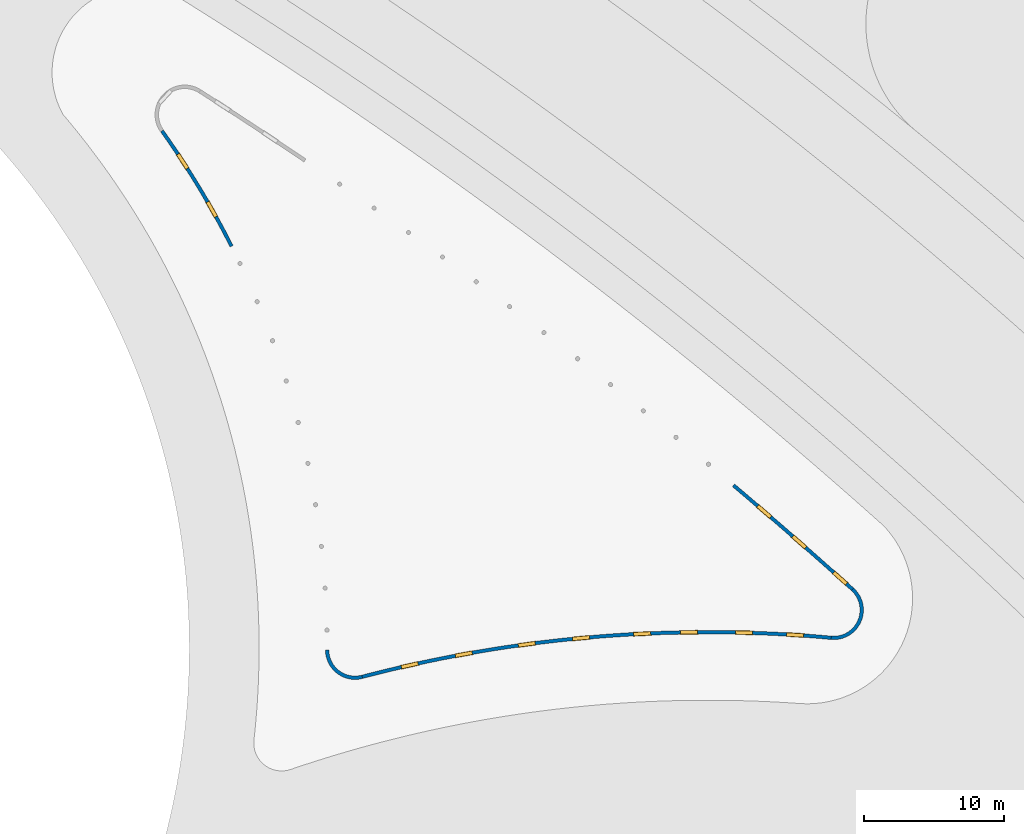
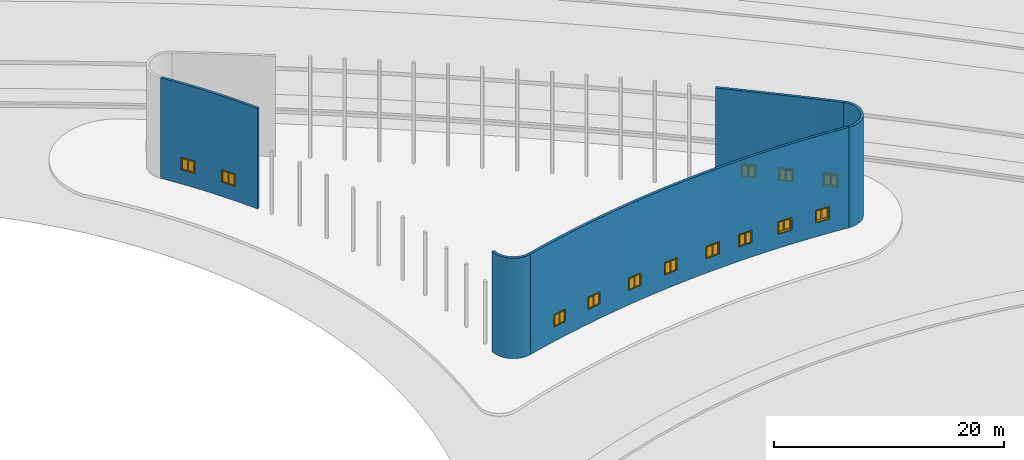
# One storey, part 13 of 39: 13 windows, 5 walls, 13 openings.
"""IFC2X3 building model written with IfcOpenShell, lengths in millimetres."""

from ifc_helpers import new_model, entity, si_unit, converted_unit, derived_unit, direction, frame, frame_2d, origin, origin_2d_with_axis, place, context, subcontext, project, spatial, polyline, circle_curve, parameter, trimmed, segment, composite_curve, rectangle, outline, extrude, clip, halfspace, source, transform, mapped, material, material_list, layer, layer_set, layer_usage, type_object, type_shapes, element, fill, save


model = new_model("IFC2X3")

# Units and contexts
model_context = context("Model", 3, precision=1e-06, world=origin(), true_north=direction((2.0, 6.12303176911189e-17, 1.0)))
context_of_model = context(None, 3, precision=1e-06, world=origin(), true_north=direction((2.0, 6.12303176911189e-17, 1.0)))
body_context = subcontext(model_context, "Body", "Model", "MODEL_VIEW")
ifc_project = project(units=[si_unit("LENGTHUNIT", "METRE", prefix="MILLI"), si_unit("AREAUNIT", "SQUARE_METRE", prefix="MILLI"), si_unit("VOLUMEUNIT", "CUBIC_METRE", prefix="MILLI"), converted_unit("PLANEANGLEUNIT", "DEGREE", entity("IfcRatioMeasure", 0.0174532925199433), si_unit("PLANEANGLEUNIT", "RADIAN"), dimensions=[0, 0, 0, 0, 0, 0, 0]), si_unit("MASSUNIT", "GRAM", prefix="KILO"), si_unit("TIMEUNIT", "SECOND"), si_unit("THERMODYNAMICTEMPERATUREUNIT", "KELVIN"), derived_unit("THERMALTRANSMITTANCEUNIT", [(si_unit("MASSUNIT", "GRAM", prefix="KILO"), 1), (si_unit("THERMODYNAMICTEMPERATUREUNIT", "KELVIN"), -1), (si_unit("TIMEUNIT", "SECOND"), -3)]), derived_unit("VOLUMETRICFLOWRATEUNIT", [(si_unit("LENGTHUNIT", "METRE"), 3), (si_unit("TIMEUNIT", "SECOND"), -1)])], contexts=[model_context, context_of_model])

# Site, building, storey
site_placement = place(None, origin())
site = spatial("IfcSite", under=ifc_project, at=site_placement, CompositionType="ELEMENT")
building_placement = place(site_placement, origin())
building = spatial("IfcBuilding", under=site, at=building_placement, CompositionType="ELEMENT")
storey_placement = place(building_placement, frame((0.0, 0.0, 4000.0)))
storey = spatial("IfcBuildingStorey", under=building, at=storey_placement, Name="Level 2", CompositionType="ELEMENT", Elevation=4000.0)

# Wall, openings, windows
ifc_material_1 = material(Name="Concrete - Cast In Situ")
ifc_layer = layer(ifc_material_1, 250.0)
ifc_layer_set = layer_set([ifc_layer], Name="Basic Wall:Structure wall")
ifc_layer_usage_1 = layer_usage(ifc_layer_set, "AXIS2", "POSITIVE", -125.0)
wall_type = type_object("IfcWallType", Name="Basic Wall:Structure wall", PredefinedType="STANDARD", material=ifc_layer_set)
wall_1_placement = place(storey_placement, frame((324246.856857284, 630373.986628821, 362.0)))
wall_1 = element("IfcWallStandardCase", 1, at=wall_1_placement, inside=storey, type_object=wall_type, material=ifc_layer_usage_1, Name="Basic Wall:Structure wall", ObjectType="Basic Wall:Structure wall", context=body_context, shape_type="Clipping", body=[
    clip(extrude(outline(composite_curve([segment(trimmed(circle_curve(frame_2d((-52045.9791286695, -37030.145578138), x_axis=(1.0, 0.0)), 64000.0), [parameter(26.776901044259)], [parameter(35.4314354354956)], True, "PARAMETER"), True, "CONTINUOUS"), segment(polyline([(101.851231171776, 72.4660383130737), (-101.851231171568, -72.4660383133509)]), True, "CONTINUOUS"), segment(trimmed(circle_curve(frame_2d((-52045.9791286695, -37030.145578138), x_axis=(1.0, 0.0)), 63750.0), [parameter(26.776901044259)], [parameter(35.4314354354956)], True, "PARAMETER"), False, "CONTINUOUS"), segment(polyline([(4867.95017362721, -8309.64503630951), (5091.14205324426, -8197.01562242035)]), True, "CONTINUOUS")], self_intersect=False)), origin(), (0.0, 0.0, 1.0), 10638.0), halfspace(frame((5091.14205324402, -8197.01562242, 10638.0)), False)),
])
opening_1_placement = place(wall_1_placement, frame((3978.539596587, -6084.61068482622, 1553.0)))
opening_1 = element("IfcOpeningElement", 2, at=opening_1_placement, cuts=wall_1, Name="M_Casement Dbl with Trim:1220 x 1220mm:1220 x 1220mm:1", ObjectType="Opening", context=body_context, shape_type="SweptSolid", body=[
    extrude(rectangle(XDim=1220.0, YDim=1220.0, at=frame_2d((610.0, 610.0), x_axis=(-1.0, 0.0))), frame((0.0, 0.0, 0.0), z_axis=(-0.870695342057725, -0.491822753966285, 0.0), x_axis=(0.0, 0.0, 1.0)), (0.0, 0.0, 1.0), 253.035095884814),
])
opening_2_placement = place(wall_1_placement, frame((1920.0419499185, -2620.24297474214, 1553.0)))
opening_2 = element("IfcOpeningElement", 3, at=opening_2_placement, cuts=wall_1, Name="M_Casement Dbl with Trim:1220 x 1220mm:1220 x 1220mm:1", ObjectType="Opening", context=body_context, shape_type="SweptSolid", body=[
    extrude(rectangle(XDim=1220.0, YDim=1220.0, at=frame_2d((610.0, 610.0), x_axis=(-1.0, 0.0))), frame((0.0, 0.0, 0.0), z_axis=(-0.838018354143229, -0.545642042111011, 0.0), x_axis=(0.0, 0.0, 1.0)), (0.0, 0.0, 1.0), 253.035095884814),
])
ifc_material_2 = material(Name="Glass")
ifc_material_3 = material(Name="Sash")
ifc_material_4 = material(Name="Trim")
ifc_material_list_1 = material_list([ifc_material_2, ifc_material_3, ifc_material_4])
ifc_material_list_2 = material_list([ifc_material_2, ifc_material_3, ifc_material_4])
window_style = type_object("IfcWindowStyle", Name="1220 x 1220mm", ConstructionType="NOTDEFINED", OperationType="NOTDEFINED", ParameterTakesPrecedence=False, Sizeable=False, material=ifc_material_list_2)
shared_shape = source(origin(), body_context, "Body", "SweptSolid", [
    extrude(rectangle(XDim=12.7, YDim=482.999999999998, at=origin_2d_with_axis()), frame((915.0, 208.775, 63.5000000000002), z_axis=(0.0, 0.0, 1.0), x_axis=(0.0, -1.0, 0.0)), (0.0, 0.0, 1.0), 1093.0),
    extrude(outline(polyline([(-285.949999999999, -590.950000000002), (285.949999999999, -590.950000000002), (285.949999999999, 590.950000000003), (-285.949999999999, 590.950000000003), (-285.949999999999, -590.950000000002)]), holes=[polyline([(-241.499999999998, -546.500000000003), (-241.499999999998, 546.500000000002), (241.5, 546.500000000002), (241.5, -546.500000000003), (-241.499999999998, -546.500000000003)])]), frame((915.0, 186.55, 610.0), z_axis=(0.0, 1.0, 0.0), x_axis=(1.0, 0.0, 0.0)), (0.0, 0.0, 1.0), 44.45),
    extrude(rectangle(XDim=25.7, YDim=1359.89999999999, at=frame_2d((-1.68753899743024e-14, 0.0), x_axis=(1.0, 0.0))), frame((610.0, 262.85, 0.0), z_axis=(0.0, 0.0, 1.0), x_axis=(0.0, -1.0, 0.0)), (0.0, 0.0, 1.0), 19.0500000000014),
    extrude(outline(polyline([(-568.700000000007, 590.949999999995), (613.200000000007, 590.949999999995), (613.200000000007, 679.949999999994), (-657.700000000005, 679.949999999994), (-657.700000000005, -679.949999999993), (613.200000000006, -679.949999999993), (613.200000000006, -590.949999999995), (-568.700000000007, -590.949999999995), (-568.700000000007, 590.949999999995)])), frame((610.0, 250.0, 632.250000000007), z_axis=(0.0, 1.0, 0.0), x_axis=(0.0, 0.0, -1.0)), (0.0, 0.0, 1.0), 13.0),
    extrude(outline(polyline([(-667.25000000001, -667.249999999998), (667.25000000001, -667.249999999998), (667.25000000001, 667.249999999998), (-667.25000000001, 667.249999999998), (-667.25000000001, -667.249999999998)]), holes=[polyline([(-578.250000000011, -578.250000000001), (-578.250000000011, 578.249999999997), (578.24999999999, 578.249999999997), (578.24999999999, -578.250000000001), (-578.250000000011, -578.250000000001)])]), frame((610.0, -19.0, 610.0), z_axis=(0.0, 1.0, 0.0), x_axis=(0.0, 0.0, -1.0)), (0.0, 0.0, 1.0), 19.0),
    extrude(rectangle(XDim=12.7, YDim=482.999999999998, at=frame_2d((1.68753899743024e-14, 4.2632564145606e-14), x_axis=(1.0, 0.0))), frame((305.0, 208.775, 63.4999999999994), z_axis=(0.0, 0.0, 1.0), x_axis=(0.0, 1.0, 0.0)), (0.0, 0.0, 1.0), 1093.0),
    extrude(outline(polyline([(-285.949999999999, -590.950000000002), (285.949999999999, -590.950000000002), (285.949999999999, 590.950000000002), (-285.949999999999, 590.950000000002), (-285.949999999999, -590.950000000002)]), holes=[polyline([(-241.499999999999, -546.500000000003), (-241.499999999999, 546.500000000001), (241.499999999999, 546.500000000001), (241.499999999999, -546.500000000003), (-241.499999999999, -546.500000000003)])]), frame((305.0, 186.55, 610.0), z_axis=(0.0, 1.0, 0.0), x_axis=(1.0, 0.0, 0.0)), (0.0, 0.0, 1.0), 44.45),
    extrude(outline(polyline([(-610.0, -610.0), (610.0, -610.0), (610.0, 610.0), (-610.0, 610.0), (-610.0, -610.0)]), holes=[polyline([(-578.25, -578.250000000001), (-578.25, 578.25), (578.249999999997, 578.25), (578.249999999997, -578.250000000001), (-578.25, -578.250000000001)])]), frame((610.0, 0.0, 610.0), z_axis=(0.0, 1.0, 0.0), x_axis=(1.0, 0.0, 0.0)), (0.0, 0.0, 1.0), 186.55),
    extrude(outline(polyline([(-610.0, -610.0), (610.0, -610.0), (610.0, 610.0), (-610.0, 610.0), (-610.0, -610.0)]), holes=[polyline([(-590.950000000002, -590.949999999996), (-590.950000000002, 590.95), (590.950000000003, 590.95), (590.950000000003, -590.949999999996), (-590.950000000002, -590.949999999996)])]), frame((610.0, 186.55, 610.0), z_axis=(0.0, 1.0, 0.0), x_axis=(0.0, 0.0, -1.0)), (0.0, 0.0, 1.0), 63.45),
    extrude(rectangle(XDim=63.5, YDim=38.0999999999998, at=frame_2d((-8.88178419700125e-15, 0.0), x_axis=(1.0, 0.0))), frame((610.0, 218.3, 19.0499999999995), z_axis=(0.0, 0.0, 1.0), x_axis=(0.0, 1.0, 0.0)), (0.0, 0.0, 1.0), 1181.90000000001),
])
type_shapes(window_style, [shared_shape])
window_1_placement = place(opening_1_placement, frame((-2.53614969894988, -1.43257471255492, 0.0), z_axis=(0.0, 0.0, 1.0), x_axis=(-0.491822753966285, 0.870695342057725, 0.0)))
window_1 = element("IfcWindow", 4, at=window_1_placement, inside=storey, type_object=window_style, material=ifc_material_list_1, Name="M_Casement Dbl with Trim:1220 x 1220mm", ObjectType="1220 x 1220mm", OverallHeight=1220.0, OverallWidth=1220.00000000006, context=body_context, shape_type="MappedRepresentation", body=[
    mapped(shared_shape, transform((0.0, 0.0, 0.0), scale=1.0)),
])
fill(opening_1, window_1)
ifc_material_list_3 = material_list([ifc_material_2, ifc_material_3, ifc_material_4])
window_2_placement = place(opening_2_placement, frame((-2.44096860737773, -1.589338812395, 0.0), z_axis=(0.0, 0.0, 1.0), x_axis=(-0.545642042111011, 0.838018354143229, 0.0)))
window_2 = element("IfcWindow", 5, at=window_2_placement, inside=storey, type_object=window_style, material=ifc_material_list_3, Name="M_Casement Dbl with Trim:1220 x 1220mm", ObjectType="1220 x 1220mm", OverallHeight=1220.0, OverallWidth=1220.00000000006, context=body_context, shape_type="MappedRepresentation", body=[
    mapped(shared_shape, transform((0.0, 0.0, 0.0), scale=1.0)),
])
fill(opening_2, window_2)

ifc_layer_usage_2 = layer_usage(ifc_layer_set, "AXIS2", "POSITIVE", -125.0)
wall_2_placement = place(storey_placement, frame((338584.140354798, 591273.768990877, 362.0)))
wall_2 = element("IfcWallStandardCase", 6, at=wall_2_placement, inside=storey, type_object=wall_type, material=ifc_layer_usage_2, Name="Basic Wall:Structure wall", ObjectType="Basic Wall:Structure wall", context=body_context, shape_type="Clipping", body=[
    clip(extrude(outline(composite_curve([segment(trimmed(circle_curve(frame_2d((24750.1675326129, -94166.1613558314), x_axis=(1.0, 0.0)), 97489.453150957), [parameter(84.7874816270728)], [parameter(104.72626174384)], True, "PARAMETER"), True, "CONTINUOUS"), segment(polyline([(-31.7751586065948, 120.893917529113), (31.7751586072185, -120.893917528836)]), True, "CONTINUOUS"), segment(trimmed(circle_curve(frame_2d((24750.1675326129, -94166.1613558314), x_axis=(1.0, 0.0)), 97239.453150957), [parameter(84.7874816270728)], [parameter(104.72626174384)], True, "PARAMETER"), False, "CONTINUOUS"), segment(polyline([(33584.3879593551, 2671.16511773909), (33607.1005007688, 2920.13126094443)]), True, "CONTINUOUS")], self_intersect=False)), origin(), (0.0, 0.0, 1.0), 10638.0), halfspace(frame((33607.1005007689, 2920.1312609444, 10638.0)), False)),
])
opening_3_placement = place(wall_2_placement, frame((3973.79947671658, 1085.65533974674, 1553.0)))
opening_3 = element("IfcOpeningElement", 7, at=opening_3_placement, cuts=wall_2, Name="M_Casement Dbl with Trim:1220 x 1220mm:1220 x 1220mm:1", ObjectType="Opening", context=body_context, shape_type="SweptSolid", body=[
    extrude(rectangle(XDim=1220.0, YDim=1220.0, at=frame_2d((610.0, 610.0), x_axis=(-1.0, 0.0))), frame((0.0, 0.0, 0.0), z_axis=(0.219218889911997, -0.975675703451588, 0.0), x_axis=(0.0, 0.0, 1.0)), (0.0, 0.0, 1.0), 251.991120195076),
])
opening_4_placement = place(wall_2_placement, frame((7857.05191083967, 1850.44500989823, 1553.0)))
opening_4 = element("IfcOpeningElement", 8, at=opening_4_placement, cuts=wall_2, Name="M_Casement Dbl with Trim:1220 x 1220mm:1220 x 1220mm:1", ObjectType="Opening", context=body_context, shape_type="SweptSolid", body=[
    extrude(rectangle(XDim=1220.0, YDim=1220.0, at=frame_2d((610.0, 610.0), x_axis=(-1.0, 0.0))), frame((0.0, 0.0, 0.0), z_axis=(0.179436995405594, -0.98376946724312, 0.0), x_axis=(0.0, 0.0, 1.0)), (0.0, 0.0, 1.0), 251.991120195076),
])
opening_5_placement = place(wall_2_placement, frame((12377.3745818733, 2536.8895164147, 1553.0)))
opening_5 = element("IfcOpeningElement", 9, at=opening_5_placement, cuts=wall_2, Name="M_Casement Dbl with Trim:1220 x 1220mm:1220 x 1220mm:1", ObjectType="Opening", context=body_context, shape_type="SweptSolid", body=[
    extrude(rectangle(XDim=1220.0, YDim=1220.0, at=frame_2d((610.0, 610.0), x_axis=(-1.0, 0.0))), frame((0.0, 0.0, 0.0), z_axis=(0.133115568133921, -0.9911005224095, 0.0), x_axis=(0.0, 0.0, 1.0)), (0.0, 0.0, 1.0), 251.991120195076),
])
opening_6_placement = place(wall_2_placement, frame((16271.7719571808, 2955.83853023235, 1553.0)))
opening_6 = element("IfcOpeningElement", 10, at=opening_6_placement, cuts=wall_2, Name="M_Casement Dbl with Trim:1220 x 1220mm:1220 x 1220mm:1", ObjectType="Opening", context=body_context, shape_type="SweptSolid", body=[
    extrude(rectangle(XDim=1220.0, YDim=1220.0, at=frame_2d((610.0, 610.0), x_axis=(-1.0, 0.0))), frame((0.0, 0.0, 0.0), z_axis=(0.0931971627082571, -0.995647673056654, 0.0), x_axis=(0.0, 0.0, 1.0)), (0.0, 0.0, 1.0), 251.991120195076),
])
opening_7_placement = place(wall_2_placement, frame((20660.8314802058, 3239.40000517386, 1553.0)))
opening_7 = element("IfcOpeningElement", 11, at=opening_7_placement, cuts=wall_2, Name="M_Casement Dbl with Trim:1220 x 1220mm:1220 x 1220mm:1", ObjectType="Opening", context=body_context, shape_type="SweptSolid", body=[
    extrude(rectangle(XDim=1220.0, YDim=1220.0, at=frame_2d((610.0, 610.0), x_axis=(-1.0, 0.0))), frame((0.0, 0.0, 0.0), z_axis=(0.0481962601317734, -0.998837884999017, 0.0), x_axis=(0.0, 0.0, 1.0)), (0.0, 0.0, 1.0), 251.991120195076),
])
opening_8_placement = place(wall_2_placement, frame((24003.0360380399, 3322.33975035998, 1553.0)))
opening_8 = element("IfcOpeningElement", 12, at=opening_8_placement, cuts=wall_2, Name="M_Casement Dbl with Trim:1220 x 1220mm:1220 x 1220mm:1", ObjectType="Opening", context=body_context, shape_type="SweptSolid", body=[
    extrude(rectangle(XDim=1220.0, YDim=1220.0, at=frame_2d((610.0, 610.0), x_axis=(-1.0, 0.0))), frame((0.0, 0.0, 0.0), z_axis=(0.0139201966296798, -0.999903109368998, 0.0), x_axis=(0.0, 0.0, 1.0)), (0.0, 0.0, 1.0), 251.991120195076),
])
opening_9_placement = place(wall_2_placement, frame((26743.0473550544, 3050.95680832148, 1553.0)))
opening_9 = element("IfcOpeningElement", 13, at=opening_9_placement, cuts=wall_2, Name="M_Casement Dbl with Trim:1220 x 1220mm:1220 x 1220mm:1", ObjectType="Opening", context=body_context, shape_type="SweptSolid", body=[
    extrude(rectangle(XDim=1220.0, YDim=1220.0, at=frame_2d((610.0, 610.0), x_axis=(-1.0, 0.0))), frame((0.0, 0.0, 0.0), z_axis=(0.0267665391308398, 0.999641712006335, 0.0), x_axis=(0.0, 0.0, 1.0)), (0.0, 0.0, 1.0), 251.991120195076),
])
opening_10_placement = place(wall_2_placement, frame((30397.5170689068, 2907.24940810782, 1553.0)))
opening_10 = element("IfcOpeningElement", 14, at=opening_10_placement, cuts=wall_2, Name="M_Casement Dbl with Trim:1220 x 1220mm:1220 x 1220mm:1", ObjectType="Opening", context=body_context, shape_type="SweptSolid", body=[
    extrude(rectangle(XDim=1220.0, YDim=1220.0, at=frame_2d((610.0, 610.0), x_axis=(-1.0, 0.0))), frame((0.0, 0.0, 0.0), z_axis=(0.0643394373933978, 0.997928071955039, 0.0), x_axis=(0.0, 0.0, 1.0)), (0.0, 0.0, 1.0), 251.991120195076),
])
ifc_material_list_4 = material_list([ifc_material_2, ifc_material_3, ifc_material_4])
window_3_placement = place(opening_3_placement, frame((0.418901081255171, -1.86439958389383, 0.0), z_axis=(0.0, 0.0, 1.0), x_axis=(-0.975675703451588, -0.219218889911997, 0.0)))
window_3 = element("IfcWindow", 15, at=window_3_placement, inside=storey, type_object=window_style, material=ifc_material_list_4, Name="M_Casement Dbl with Trim:1220 x 1220mm", ObjectType="1220 x 1220mm", OverallHeight=1220.0, OverallWidth=1220.00000000004, context=body_context, shape_type="MappedRepresentation", body=[
    mapped(shared_shape, transform((0.0, 0.0, 0.0), scale=1.0)),
])
fill(opening_3, window_3)
ifc_material_list_5 = material_list([ifc_material_2, ifc_material_3, ifc_material_4])
window_4_placement = place(opening_4_placement, frame((0.342882638564333, -1.87986579863355, 0.0), z_axis=(0.0, 0.0, 1.0), x_axis=(-0.98376946724312, -0.179436995405594, 0.0)))
window_4 = element("IfcWindow", 16, at=window_4_placement, inside=storey, type_object=window_style, material=ifc_material_list_5, Name="M_Casement Dbl with Trim:1220 x 1220mm", ObjectType="1220 x 1220mm", OverallHeight=1220.0, OverallWidth=1220.00000000001, context=body_context, shape_type="MappedRepresentation", body=[
    mapped(shared_shape, transform((0.0, 0.0, 0.0), scale=1.0)),
])
fill(opening_4, window_4)
ifc_material_list_6 = material_list([ifc_material_2, ifc_material_3, ifc_material_4])
window_5_placement = place(opening_5_placement, frame((0.254367930814624, -1.89387456828263, 0.0), z_axis=(0.0, 0.0, 1.0), x_axis=(-0.9911005224095, -0.133115568133921, 0.0)))
window_5 = element("IfcWindow", 17, at=window_5_placement, inside=storey, type_object=window_style, material=ifc_material_list_6, Name="M_Casement Dbl with Trim:1220 x 1220mm", ObjectType="1220 x 1220mm", OverallHeight=1220.0, OverallWidth=1220.00000000003, context=body_context, shape_type="MappedRepresentation", body=[
    mapped(shared_shape, transform((0.0, 0.0, 0.0), scale=1.0)),
])
fill(opening_5, window_5)
ifc_material_list_7 = material_list([ifc_material_2, ifc_material_3, ifc_material_4])
window_6_placement = place(opening_6_placement, frame((0.178088632121217, -1.90256362932269, 0.0), z_axis=(0.0, 0.0, 1.0), x_axis=(-0.995647673056654, -0.0931971627082571, 0.0)))
window_6 = element("IfcWindow", 18, at=window_6_placement, inside=storey, type_object=window_style, material=ifc_material_list_7, Name="M_Casement Dbl with Trim:1220 x 1220mm", ObjectType="1220 x 1220mm", OverallHeight=1220.0, OverallWidth=1220.00000000002, context=body_context, shape_type="MappedRepresentation", body=[
    mapped(shared_shape, transform((0.0, 0.0, 0.0), scale=1.0)),
])
fill(opening_6, window_6)
ifc_material_list_8 = material_list([ifc_material_2, ifc_material_3, ifc_material_4])
window_7_placement = place(opening_7_placement, frame((0.092097289103549, -1.90865974279586, 0.0), z_axis=(0.0, 0.0, 1.0), x_axis=(-0.998837884999017, -0.0481962601317734, 0.0)))
window_7 = element("IfcWindow", 19, at=window_7_placement, inside=storey, type_object=window_style, material=ifc_material_list_8, Name="M_Casement Dbl with Trim:1220 x 1220mm", ObjectType="1220 x 1220mm", OverallHeight=1220.0, OverallWidth=1219.99999999996, context=body_context, shape_type="MappedRepresentation", body=[
    mapped(shared_shape, transform((0.0, 0.0, 0.0), scale=1.0)),
])
fill(opening_7, window_7)
ifc_material_list_9 = material_list([ifc_material_2, ifc_material_3, ifc_material_4])
window_8_placement = place(opening_8_placement, frame((0.026599831006024, -1.91069525922649, 0.0), z_axis=(0.0, 0.0, 1.0), x_axis=(-0.999903109368998, -0.0139201966296798, 0.0)))
window_8 = element("IfcWindow", 20, at=window_8_placement, inside=storey, type_object=window_style, material=ifc_material_list_9, Name="M_Casement Dbl with Trim:1220 x 1220mm", ObjectType="1220 x 1220mm", OverallHeight=1220.0, OverallWidth=1219.99999999998, context=body_context, shape_type="MappedRepresentation", body=[
    mapped(shared_shape, transform((0.0, 0.0, 0.0), scale=1.0)),
])
fill(opening_8, window_8)
ifc_material_list_10 = material_list([ifc_material_2, ifc_material_3, ifc_material_4])
window_9_placement = place(opening_9_placement, frame((0.0511476551764645, 1.91019576019607, 0.0), z_axis=(0.0, 0.0, 1.0), x_axis=(0.999641712006335, -0.0267665391308398, 0.0)))
window_9 = element("IfcWindow", 21, at=window_9_placement, inside=storey, type_object=window_style, material=ifc_material_list_10, Name="M_Casement Dbl with Trim:1220 x 1220mm", ObjectType="1220 x 1220mm", OverallHeight=1220.0, OverallWidth=1220.00000000001, context=body_context, shape_type="MappedRepresentation", body=[
    mapped(shared_shape, transform((0.0, 0.0, 0.0), scale=1.0)),
])
fill(opening_9, window_9)
ifc_material_list_11 = material_list([ifc_material_2, ifc_material_3, ifc_material_4])
window_10_placement = place(opening_10_placement, frame((0.122944970207755, 1.90692119894084, 0.0), z_axis=(0.0, 0.0, 1.0), x_axis=(0.997928071955039, -0.0643394373933978, 0.0)))
window_10 = element("IfcWindow", 22, at=window_10_placement, inside=storey, type_object=window_style, material=ifc_material_list_11, Name="M_Casement Dbl with Trim:1220 x 1220mm", ObjectType="1220 x 1220mm", OverallHeight=1220.0, OverallWidth=1220.00000000002, context=body_context, shape_type="MappedRepresentation", body=[
    mapped(shared_shape, transform((0.0, 0.0, 0.0), scale=1.0)),
])
fill(opening_10, window_10)

ifc_layer_usage_3 = layer_usage(ifc_layer_set, "AXIS2", "NEGATIVE", 125.0)
wall_3_placement = place(storey_placement, frame((373700.989001261, 597546.406133717, 362.0)))
wall_3 = element("IfcWallStandardCase", 23, at=wall_3_placement, inside=storey, type_object=wall_type, material=ifc_layer_usage_3, Name="Basic Wall:Structure wall", ObjectType="Basic Wall:Structure wall", context=body_context, shape_type="Clipping", body=[
    clip(extrude(outline(composite_curve([segment(trimmed(circle_curve(frame_2d((-240440.045924685, -266623.000769375), x_axis=(1.0, 0.0)), 358900.40331226), [parameter(47.9559275311233)], [parameter(49.761313392049)], True, "PARAMETER"), False, "CONTINUOUS"), segment(polyline([(-83.7127553201221, -92.828737989368), (83.7127553184588, 92.828737990962)]), True, "CONTINUOUS"), segment(trimmed(circle_curve(frame_2d((-240440.045924685, -266623.000769375), x_axis=(1.0, 0.0)), 359150.40331226), [parameter(47.9559275311233)], [parameter(49.761313392049)], True, "PARAMETER"), True, "CONTINUOUS"), segment(polyline([(-8438.48825408556, 7538.06400418903), (-8599.98156965301, 7347.22399521023)]), True, "CONTINUOUS")], self_intersect=False)), origin(), (0.0, 0.0, 1.0), 10638.0), halfspace(frame((-8599.98156965128, 7347.2239952088, 10638.0)), False)),
])
opening_11_placement = place(wall_3_placement, frame((-1588.85074146567, 921.102441322137, 1553.0)))
opening_11 = element("IfcOpeningElement", 24, at=opening_11_placement, cuts=wall_3, Name="M_Casement Dbl with Trim:1220 x 1220mm:1220 x 1220mm:1", ObjectType="Opening", context=body_context, shape_type="SweptSolid", body=[
    extrude(rectangle(XDim=1220.0, YDim=1220.0, at=frame_2d((610.0, 610.0), x_axis=(-1.0, 0.0))), frame((0.0, 0.0, 0.0), z_axis=(0.667240962144463, 0.744841928489885, 0.0), x_axis=(0.0, 0.0, 1.0)), (0.0, 0.0, 1.0), 250.539969129551),
])
opening_12_placement = place(wall_3_placement, frame((-3107.34204607467, 3269.95864407469, 1553.0)))
opening_12 = element("IfcOpeningElement", 25, at=opening_12_placement, cuts=wall_3, Name="M_Casement Dbl with Trim:1220 x 1220mm:1220 x 1220mm:1", ObjectType="Opening", context=body_context, shape_type="SweptSolid", body=[
    extrude(rectangle(XDim=1220.0, YDim=1220.0, at=frame_2d((610.0, 610.0), x_axis=(-1.0, 0.0))), frame((0.0, 0.0, 0.0), z_axis=(-0.659080896578437, -0.752072052243243, 0.0), x_axis=(0.0, 0.0, 1.0)), (0.0, 0.0, 1.0), 250.539969129551),
])
opening_13_placement = place(wall_3_placement, frame((-5610.34763025465, 5450.58242132897, 1553.0)))
opening_13 = element("IfcOpeningElement", 26, at=opening_13_placement, cuts=wall_3, Name="M_Casement Dbl with Trim:1220 x 1220mm:1220 x 1220mm:1", ObjectType="Opening", context=body_context, shape_type="SweptSolid", body=[
    extrude(rectangle(XDim=1220.0, YDim=1220.0, at=frame_2d((610.0, 610.0), x_axis=(-1.0, 0.0))), frame((0.0, 0.0, 0.0), z_axis=(-0.6521062258451, -0.758127608133393, 0.0), x_axis=(0.0, 0.0, 1.0)), (0.0, 0.0, 1.0), 250.539969129551),
])
ifc_material_list_12 = material_list([ifc_material_2, ifc_material_3, ifc_material_4])
window_11_placement = place(opening_11_placement, frame((167.156010694627, 186.596465786919, 0.0), z_axis=(0.0, 0.0, 1.0), x_axis=(0.744841928489885, -0.667240962144463, 0.0)))
window_11 = element("IfcWindow", 27, at=window_11_placement, inside=storey, type_object=window_style, material=ifc_material_list_12, Name="M_Casement Dbl with Trim:1220 x 1220mm", ObjectType="1220 x 1220mm", OverallHeight=1220.0, OverallWidth=1220.00000000002, context=body_context, shape_type="MappedRepresentation", body=[
    mapped(shared_shape, transform((0.0, 0.0, 0.0), scale=1.0)),
])
fill(opening_11, window_11)
ifc_material_list_13 = material_list([ifc_material_2, ifc_material_3, ifc_material_4])
window_12_placement = place(opening_12_placement, frame((-165.111765685084, -188.407743439311, 0.0), z_axis=(0.0, 0.0, 1.0), x_axis=(-0.752072052243243, 0.659080896578437, 0.0)))
window_12 = element("IfcWindow", 28, at=window_12_placement, inside=storey, type_object=window_style, material=ifc_material_list_13, Name="M_Casement Dbl with Trim:1220 x 1220mm", ObjectType="1220 x 1220mm", OverallHeight=1220.0, OverallWidth=1220.00000000004, context=body_context, shape_type="MappedRepresentation", body=[
    mapped(shared_shape, transform((0.0, 0.0, 0.0), scale=1.0)),
])
fill(opening_12, window_12)
ifc_material_list_14 = material_list([ifc_material_2, ifc_material_3, ifc_material_4])
window_13_placement = place(opening_13_placement, frame((-163.364483665791, -189.924770454294, 0.0), z_axis=(0.0, 0.0, 1.0), x_axis=(-0.758127608133393, 0.6521062258451, 0.0)))
window_13 = element("IfcWindow", 29, at=window_13_placement, inside=storey, type_object=window_style, material=ifc_material_list_14, Name="M_Casement Dbl with Trim:1220 x 1220mm", ObjectType="1220 x 1220mm", OverallHeight=1220.0, OverallWidth=1220.00000000002, context=body_context, shape_type="MappedRepresentation", body=[
    mapped(shared_shape, transform((0.0, 0.0, 0.0), scale=1.0)),
])
fill(opening_13, window_13)

# Walls
ifc_layer_usage_4 = layer_usage(ifc_layer_set, "AXIS2", "POSITIVE", -125.0)
wall_4_placement = place(storey_placement, frame((338584.140354801, 591273.768990878, 362.0)))
element("IfcWallStandardCase", 30, at=wall_4_placement, inside=storey, type_object=wall_type, material=ifc_layer_usage_4, Name="Basic Wall:Structure wall", ObjectType="Basic Wall:Structure wall", context=body_context, shape_type="Clipping", body=[
    clip(extrude(outline(composite_curve([segment(trimmed(circle_curve(frame_2d((-508.402537715427, 1934.30268046255), x_axis=(1.0, 0.0)), 2125.0), [parameter(179.881912441284)], [parameter(284.726261743839)], True, "PARAMETER"), True, "CONTINUOUS"), segment(polyline([(31.7751586072185, -120.893917528905), (-31.7751586072185, 120.893917528905)]), True, "CONTINUOUS"), segment(trimmed(circle_curve(frame_2d((-508.402537715427, 1934.30268046255), x_axis=(1.0, 0.0)), 1875.0), [parameter(179.881912441284)], [parameter(284.726261743839)], True, "PARAMETER"), False, "CONTINUOUS"), segment(polyline([(-2383.39855541384, 1938.16708404902), (-2633.3980244403, 1938.68233786055)]), True, "CONTINUOUS")], self_intersect=False)), origin(), (0.0, 0.0, 1.0), 10638.0), halfspace(frame((-2633.3980244403, 1938.68233786055, 10638.0)), False)),
])
ifc_layer_usage_5 = layer_usage(ifc_layer_set, "AXIS2", "NEGATIVE", 125.0)
wall_5_placement = place(storey_placement, frame((372179.88458486, 594069.417180219, 362.0)))
element("IfcWallStandardCase", 31, at=wall_5_placement, inside=storey, type_object=wall_type, material=ifc_layer_usage_5, Name="Basic Wall:Structure wall", ObjectType="Basic Wall:Structure wall", context=body_context, shape_type="Clipping", body=[
    clip(extrude(outline(composite_curve([segment(trimmed(circle_curve(frame_2d((181.700331305435, 1991.72914564292), x_axis=(1.0, 0.0)), 1875.0), [parameter(264.787481627071)], [parameter(47.9559275311218)], True, "PARAMETER"), False, "CONTINUOUS"), segment(polyline([(11.356270706607, 124.48307160267), (-11.356270706607, -124.48307160267)]), True, "CONTINUOUS"), segment(trimmed(circle_curve(frame_2d((181.700331305435, 1991.72914564292), x_axis=(1.0, 0.0)), 2125.0), [parameter(264.787481627071)], [parameter(47.9559275311218)], True, "PARAMETER"), True, "CONTINUOUS"), segment(polyline([(1604.8171717191, 3569.81769148914), (1437.39166108218, 3384.16021550728)]), True, "CONTINUOUS")], self_intersect=False)), origin(), (0.0, 0.0, 1.0), 10638.0), halfspace(frame((1437.39166108215, 3384.16021550727, 10638.0)), False)),
])

save(model, "model.ifc")
